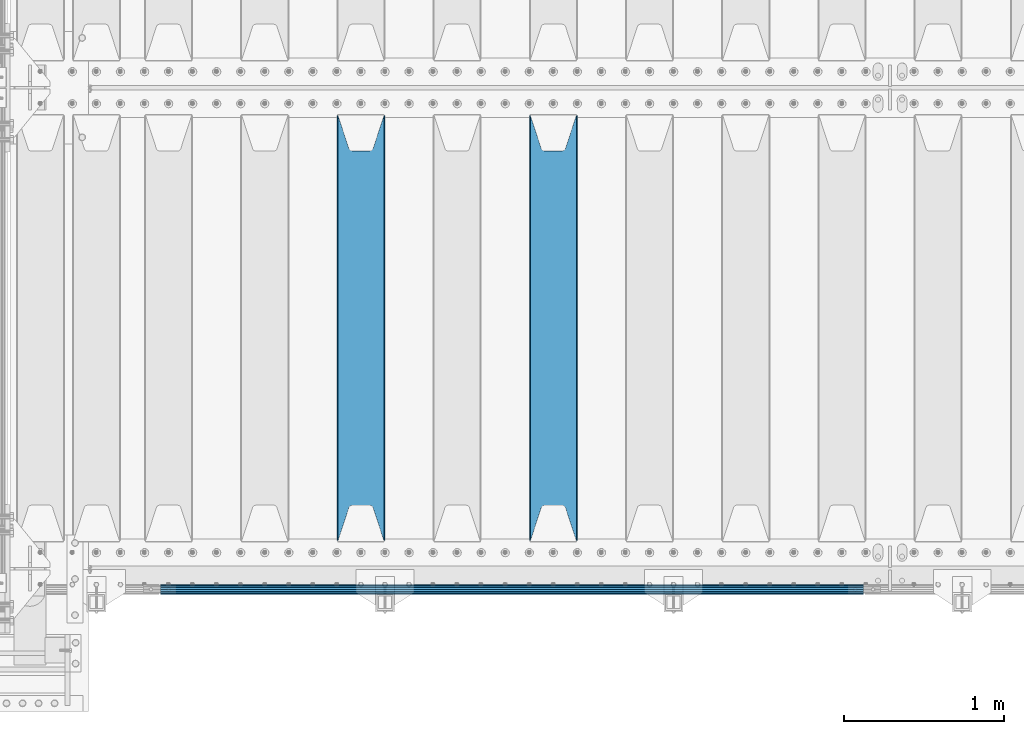
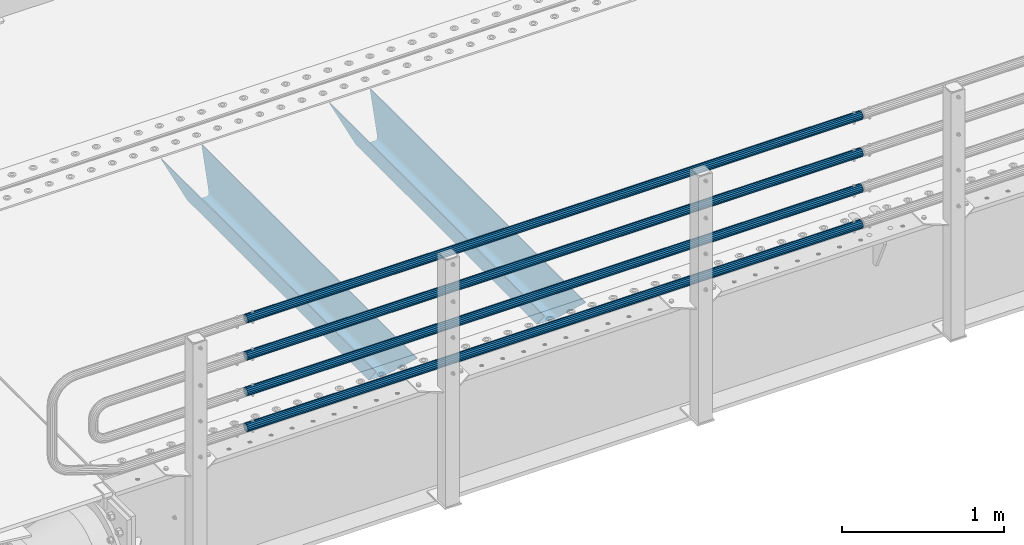
# One storey, part 91 of 208: 6 beams.
"""IFC2X3 building model written with IfcOpenShell, lengths in millimetres."""

import ifcopenshell
import ifcopenshell.guid

model = None  # the IFC model being written
_history = None  # IfcOwnerHistory: only IFC2X3 demands one
_inside = {}  # id of a spatial element -> (the spatial element, [elements in it])
_under = {}  # id of a project, library or spatial element -> (it, [spatial elements below it])
_declared = {}  # id of a project -> (the project, [libraries it declares])
_typed = {}  # id of a type object -> (the type object, [elements of that type])
_made_of = {}  # id of a material, layer set ... -> (it, [elements and type objects made of it])


def new_model(schema):
    """Start an empty IFC model of exactly this schema.

    Asked for "IFC4X3", IfcOpenShell would pick the latest addendum, in which some entities
    have other attributes; the version numbers below select the first issue.
    IFC2X3 requires an IfcOwnerHistory on every rooted entity: one is made here for all.
    """
    global model, _history
    if schema == "IFC4X3":
        model = ifcopenshell.file(schema_version=(4, 3, 0, 0))
    else:
        model = ifcopenshell.file(schema=schema)
    _inside.clear()
    _under.clear()
    _declared.clear()
    _typed.clear()
    _made_of.clear()
    _history = None
    if model.schema == "IFC2X3":
        org = make("IfcOrganization", Name="unknown")
        user = make(
            "IfcPersonAndOrganization",
            ThePerson=make("IfcPerson", FamilyName="unknown"),
            TheOrganization=org,
        )
        app = make(
            "IfcApplication",
            ApplicationDeveloper=org,
            Version="unknown",
            ApplicationFullName="unknown",
            ApplicationIdentifier="unknown",
        )
        _history = make(
            "IfcOwnerHistory",
            OwningUser=user,
            OwningApplication=app,
            ChangeAction="ADDED",
            CreationDate=0,
        )
    return model


def make(cls, **values):
    """One entity of the class cls with the attributes given. An attribute that is None is left unset."""
    return model.create_entity(
        cls, **{name: value for name, value in values.items() if value is not None}
    )


def rooted(cls, **values):
    """An entity with a GlobalId (a new one), such as an element, a storey or a relation."""
    return make(cls, GlobalId=ifcopenshell.guid.new(), OwnerHistory=_history, **values)


def si_unit(unit_type, name, prefix=None):
    """IfcSIUnit, for example si_unit("LENGTHUNIT", "METRE", prefix="MILLI")."""
    return make("IfcSIUnit", UnitType=unit_type, Prefix=prefix, Name=name)


def assignment(units):
    """IfcUnitAssignment: the units of a project."""
    return None if units is None else make("IfcUnitAssignment", Units=units)


def point(xyz):
    """IfcCartesianPoint."""
    return None if xyz is None else make("IfcCartesianPoint", Coordinates=xyz)


def direction(xyz):
    """IfcDirection."""
    return None if xyz is None else make("IfcDirection", DirectionRatios=xyz)


def frame(location, z_axis=None, x_axis=None):
    """IfcAxis2Placement3D, a coordinate frame: its origin and axes. An axis left out is left unset."""
    return make(
        "IfcAxis2Placement3D",
        Location=point(location),
        Axis=direction(z_axis),
        RefDirection=direction(x_axis),
    )


def origin_with_axes():
    """The frame at (0, 0, 0) with the z axis (0, 0, 1) and the x axis (1, 0, 0) written out."""
    return frame((0.0, 0.0, 0.0), z_axis=(0.0, 0.0, 1.0), x_axis=(1.0, 0.0, 0.0))


def place(relative_to, where):
    """IfcLocalPlacement: puts the frame where relative to a parent placement (None: the world)."""
    return make(
        "IfcLocalPlacement", PlacementRelTo=relative_to, RelativePlacement=where
    )


def context(
    kind, dimensions, precision=None, world=None, true_north=None, identifier=None
):
    """IfcGeometricRepresentationContext, for example the 3D "Model" context."""
    return make(
        "IfcGeometricRepresentationContext",
        ContextIdentifier=identifier,
        ContextType=kind,
        CoordinateSpaceDimension=dimensions,
        Precision=precision,
        WorldCoordinateSystem=world,
        TrueNorth=true_north,
    )


def subcontext(parent, identifier, kind, view, scale=None):
    """IfcGeometricRepresentationSubContext, for example "Body" below "Model"."""
    return make(
        "IfcGeometricRepresentationSubContext",
        ContextIdentifier=identifier,
        ContextType=kind,
        ParentContext=parent,
        TargetScale=scale,
        TargetView=view,
    )


def project(units=None, contexts=None):
    """IfcProject with its units and contexts."""
    return rooted(
        "IfcProject",
        Name="project",
        RepresentationContexts=contexts,
        UnitsInContext=assignment(units),
    )


def spatial(cls, under=None, at=None, **own):
    """A site, building, storey or space (cls), placed at a placement, below another one or the project."""
    s = rooted(cls, ObjectPlacement=at, **own)
    if under is not None:
        _under.setdefault(under.id(), (under, []))[1].append(s)
    return s


def faces_of(points, faces, orient=None, outer=None):
    """IfcFace entities. A face is a list of loops; a loop is a list of indices into points, from 0.

    orient and outer hold one flag for each loop. By default every Orientation is true, the
    first loop of a face is its IfcFaceOuterBound and the others are IfcFaceBound.
    """
    made = []
    for i, loops in enumerate(faces):
        bounds = []
        for j, loop in enumerate(loops):
            is_outer = j == 0 if outer is None else outer[i][j]
            bounds.append(
                make(
                    "IfcFaceOuterBound" if is_outer else "IfcFaceBound",
                    Bound=make("IfcPolyLoop", Polygon=[points[k] for k in loop]),
                    Orientation=True if orient is None else orient[i][j],
                )
            )
        made.append(make("IfcFace", Bounds=bounds))
    return made


def faceted_brep(points, faces, orient=None, outer=None, voids=None):
    """IfcFacetedBrep: a solid bounded by flat faces; with voids (closed shells), ...WithVoids."""
    shared = [point(p) for p in points]
    hull = make("IfcClosedShell", CfsFaces=faces_of(shared, faces, orient, outer))
    if voids is None:
        return make("IfcFacetedBrep", Outer=hull)
    return make(
        "IfcFacetedBrepWithVoids",
        Outer=hull,
        Voids=[
            make(cls, CfsFaces=faces_of(shared, fs, o, b)) for cls, fs, o, b in voids
        ],
    )


def shape(context_of_items, identifier, shape_type, items):
    """IfcShapeRepresentation: the items that make up one representation, for example the "Body"."""
    return make(
        "IfcShapeRepresentation",
        ContextOfItems=context_of_items,
        RepresentationIdentifier=identifier,
        RepresentationType=shape_type,
        Items=items,
    )


def material(Name=None, Category=None):
    """IfcMaterial."""
    return make("IfcMaterial", Name=Name, Category=Category)


def made_of(thing, what):
    """Note that an element or type object is made of a material, layer set ...; save() writes the relation."""
    if what is not None:
        _made_of.setdefault(what.id(), (what, []))[1].append(thing)
    return thing


def type_object(cls, material=None, **own):
    """A type object (cls), such as IfcWallType, which elements share."""
    return made_of(rooted(cls, **own), material)


def element(
    cls,
    number,
    at=None,
    inside=None,
    cuts=None,
    type_object=None,
    material=None,
    context=None,
    identifier="Body",
    shape_type=None,
    held_by="IfcProductDefinitionShape",
    body=None,
    shapes=None,
    **own,
):
    """One element of the class cls, such as IfcWall. Its Tag is "e" and its number.

    at: its placement. inside: the storey or other place that contains it. cuts: it is an
    opening in that element (IfcRelVoidsElement). A single representation is given by context,
    identifier, shape_type and body (its items); several are given by shapes. held_by: the class
    of the entity that holds the representations. save() writes the other relations.
    """
    e = rooted(cls, Tag="e%d" % number, ObjectPlacement=at, **own)
    if body is not None:
        shapes = [shape(context, identifier, shape_type, body)]
    if shapes is not None:
        e.Representation = make(held_by, Representations=shapes)
    if inside is not None:
        _inside.setdefault(inside.id(), (inside, []))[1].append(e)
    if cuts is not None:
        rooted(
            "IfcRelVoidsElement", RelatingBuildingElement=cuts, RelatedOpeningElement=e
        )
    if type_object is not None:
        _typed.setdefault(type_object.id(), (type_object, []))[1].append(e)
    return made_of(e, material)


def aggregate(whole, parts):
    """IfcRelAggregates: a whole, such as a stair, and the parts it consists of."""
    return rooted("IfcRelAggregates", RelatingObject=whole, RelatedObjects=parts)


def save(model, path):
    """Write the relations noted so far, then the file.

    IfcRelAggregates (storeys below a building ...), IfcRelContainedInSpatialStructure (elements
    in a storey), IfcRelDefinesByType, IfcRelAssociatesMaterial and IfcRelDeclares: one each for
    every whole, place, type object, material and project.
    """
    for whole, parts in _under.values():
        aggregate(whole, parts)
    for where, things in _inside.values():
        rooted(
            "IfcRelContainedInSpatialStructure",
            RelatedElements=things,
            RelatingStructure=where,
        )
    for kind, things in _typed.values():
        rooted("IfcRelDefinesByType", RelatedObjects=things, RelatingType=kind)
    for what, things in _made_of.values():
        rooted("IfcRelAssociatesMaterial", RelatedObjects=things, RelatingMaterial=what)
    for by, libraries in _declared.values():
        rooted("IfcRelDeclares", RelatingContext=by, RelatedDefinitions=libraries)
    model.write(path)


model = new_model("IFC2X3")

# Units and contexts
model_context = context("Model", 3, precision=1e-05, world=origin_with_axes())
body_context = subcontext(model_context, "Body", "Model", "MODEL_VIEW")
ifc_project = project(units=[si_unit("LENGTHUNIT", "METRE", prefix="MILLI"), si_unit("AREAUNIT", "SQUARE_METRE"), si_unit("VOLUMEUNIT", "CUBIC_METRE"), si_unit("MASSUNIT", "GRAM", prefix="KILO"), si_unit("TIMEUNIT", "SECOND"), si_unit("PLANEANGLEUNIT", "RADIAN"), si_unit("SOLIDANGLEUNIT", "STERADIAN"), si_unit("THERMODYNAMICTEMPERATUREUNIT", "DEGREE_CELSIUS"), si_unit("LUMINOUSINTENSITYUNIT", "LUMEN")], contexts=[model_context])

# Site, building, storey
site_placement = place(None, origin_with_axes())
site = spatial("IfcSite", under=ifc_project, at=site_placement, CompositionType="ELEMENT")
building_placement = place(site_placement, origin_with_axes())
building = spatial("IfcBuilding", under=site, at=building_placement, Name="Standard", CompositionType="ELEMENT")
storey_placement = place(building_placement, origin_with_axes())
storey = spatial("IfcBuildingStorey", under=building, at=storey_placement, Name="Undefined", CompositionType="ELEMENT", Elevation=0.0)

# Beams
ifc_material_1 = material(Name="STEEL/S355N")
beam_type_1 = type_object("IfcBeamType", PredefinedType="NOTDEFINED")
beam_1_placement = place(storey_placement, frame((-39050.0, 175.0, -115.0), z_axis=(0.0, 0.0, 1.0), x_axis=(0.0, 1.0, 0.0)))
element("IfcBeam", 1, at=beam_1_placement, inside=storey, type_object=beam_type_1, material=ifc_material_1, context=body_context, shape_type="Brep", body=[
    faceted_brep([(0.0, 150.0, 115.0), (0.0, 143.689999999999, 115.0), (2650.00000000297, 143.689999999999, 115.0), (2650.00000000297, 150.0, 115.0), (2650.00000000297, 142.059565218402, 110.0000000031), (2650.00000000297, 148.369565218403, 110.0000000031), (2441.90079219208, -80.1103600731112, -98.0992078077845), (2437.7588105432, -77.5672621345584, -102.241189456673), (2434.06523489746, -74.4080125315522, -105.934765102404), (2430.91086095089, -70.710272125576, -109.089139048974), (2428.37322971128, -66.5649389910068, -111.626770288588), (2426.51472138055, -62.0739139532889, -113.485278619323), (2425.38102192091, -57.3475956567672, -114.618978078955), (2424.99999999987, -52.5021667386536, -115.0), (2424.99999999987, 52.5021667386536, -115.0), (2425.38102192091, 57.3475956567672, -114.618978078955), (2426.51472138055, 62.0739139532889, -113.485278619323), (2428.37322971128, 66.5649389910068, -111.626770288588), (2430.91086095089, 70.710272125576, -109.089139048974), (2434.06523489746, 74.4080125315522, -105.934765102404), (2437.7588105432, 77.5672621345584, -102.241189456673), (2441.90079219208, 80.1103600731112, -98.0992078077846), (2446.38936140511, 81.9747917625791, -93.6106385947584), (2448.24948500409, 76.2713538057251, -91.7505149957729), (2444.62967112262, 74.76777986261, -95.3703288772456), (2441.28936334126, 72.7168944282894, -98.710636658607), (2438.31067330438, 70.1691124903846, -101.689326695487), (2435.76682334747, 67.1870637758839, -104.233176652398), (2433.72034654133, 63.8440531834895, -106.279653458539), (2432.22154950041, 60.222258798236, -107.778450499454), (2431.30727574265, 56.4107117849089, -108.692724257221), (2430.99999999987, 52.5031078186876, -109.0), (2430.99999999987, -52.5031078186876, -109.0), (2431.30727574265, -56.4107117849089, -108.692724257221), (2432.22154950041, -60.222258798236, -107.778450499454), (2433.72034654133, -63.8440531834895, -106.279653458539), (2435.76682334747, -67.1870637758839, -104.233176652398), (2438.31067330438, -70.1691124903846, -101.689326695487), (2441.28936334126, -72.7168944282894, -98.7106366586071), (2444.62967112262, -74.76777986261, -95.3703288772457), (2448.24948500409, -76.2713538057251, -91.7505149957729), (2650.00000000297, -142.059565218402, 110.0000000031), (2650.00000000297, -148.369565218403, 110.0000000031), (2446.38936140511, -81.9747917625791, -93.6106385947584), (2650.00000000297, -143.689999999999, 115.0), (2650.00000000297, -150.0, 115.0), (0.0, -143.689999999999, 115.0), (0.0, -150.0, 115.0), (0.0, -148.369565218261, 110.000000002663), (203.610638597421, -81.9747917625791, -93.6106385947584), (208.099207810448, -80.1103600731112, -98.0992078077845), (212.241189459336, -77.5672621345584, -102.241189456673), (215.934765105067, -74.4080125315522, -105.934765102404), (219.089139051637, -70.710272125576, -109.089139048974), (221.626770291251, -66.5649389910068, -111.626770288588), (223.485278621986, -62.0739139532889, -113.485278619323), (224.618978081618, -57.3475956567672, -114.618978078955), (225.000000002663, -52.5021667386536, -115.0), (225.000000002663, 52.5021667386536, -115.0), (224.618978081618, 57.3475956567672, -114.618978078955), (223.485278621986, 62.0739139532889, -113.485278619323), (221.626770291251, 66.5649389910068, -111.626770288588), (219.089139051637, 70.710272125576, -109.089139048974), (215.934765105067, 74.4080125315522, -105.934765102404), (212.241189459336, 77.5672621345584, -102.241189456673), (208.099207810448, 80.1103600731112, -98.0992078077846), (203.610638597421, 81.9747917625791, -93.6106385947584), (0.0, 148.369565218261, 110.000000002663), (0.0, 142.05956521826, 110.000000002663), (201.750514998436, 76.2713538057251, -91.7505149957729), (205.370328879908, 74.76777986261, -95.3703288772456), (208.71063666127, 72.7168944282894, -98.710636658607), (211.68932669815, 70.1691124903846, -101.689326695487), (214.233176655061, 67.1870637758839, -104.233176652398), (216.279653461202, 63.8440531834895, -106.279653458539), (217.778450502116, 60.222258798236, -107.778450499454), (218.692724259884, 56.4107117849089, -108.692724257221), (219.000000002663, 52.5031078186876, -109.0), (219.000000002663, -52.5031078186876, -109.0), (218.692724259884, -56.4107117849089, -108.692724257221), (217.778450502116, -60.222258798236, -107.778450499454), (216.279653461202, -63.8440531834895, -106.279653458539), (214.233176655061, -67.1870637758839, -104.233176652398), (211.68932669815, -70.1691124903846, -101.689326695487), (208.71063666127, -72.7168944282894, -98.7106366586071), (205.370328879908, -74.76777986261, -95.3703288772457), (201.750514998436, -76.2713538057251, -91.7505149957729), (0.0, -142.05956521826, 110.000000002663)], [[[0, 1, 2, 3]], [[3, 2, 4, 5]], [[6, 7, 8, 9, 10, 11, 12, 13, 14, 15, 16, 17, 18, 19, 20, 21, 22, 5, 4, 23, 24, 25, 26, 27, 28, 29, 30, 31, 32, 33, 34, 35, 36, 37, 38, 39, 40, 41, 42, 43]], [[44, 45, 42, 41]], [[46, 47, 45, 44]], [[43, 42, 45, 47, 48, 49]], [[6, 43, 49, 50]], [[7, 6, 50, 51]], [[8, 7, 51, 52]], [[9, 8, 52, 53]], [[10, 9, 53, 54]], [[11, 10, 54, 55]], [[12, 11, 55, 56]], [[13, 12, 56, 57]], [[14, 13, 57, 58]], [[15, 14, 58, 59]], [[16, 15, 59, 60]], [[17, 16, 60, 61]], [[18, 17, 61, 62]], [[19, 18, 62, 63]], [[20, 19, 63, 64]], [[21, 20, 64, 65]], [[22, 21, 65, 66]], [[0, 3, 5, 22, 66, 67]], [[1, 0, 67, 68]], [[23, 4, 2, 1, 68, 69]], [[24, 23, 69, 70]], [[25, 24, 70, 71]], [[26, 25, 71, 72]], [[27, 26, 72, 73]], [[28, 27, 73, 74]], [[29, 28, 74, 75]], [[30, 29, 75, 76]], [[31, 30, 76, 77]], [[32, 31, 77, 78]], [[33, 32, 78, 79]], [[34, 33, 79, 80]], [[35, 34, 80, 81]], [[36, 35, 81, 82]], [[37, 36, 82, 83]], [[38, 37, 83, 84]], [[39, 38, 84, 85]], [[40, 39, 85, 86]], [[46, 44, 41, 40, 86, 87]], [[47, 46, 87, 48]], [[86, 85, 84, 83, 82, 81, 80, 79, 78, 77, 76, 75, 74, 73, 72, 71, 70, 69, 68, 67, 66, 65, 64, 63, 62, 61, 60, 59, 58, 57, 56, 55, 54, 53, 52, 51, 50, 49, 48, 87]]]),
])
beam_2_placement = place(storey_placement, frame((-40250.0, 175.0, -115.0), z_axis=(0.0, 0.0, 1.0), x_axis=(0.0, 1.0, 0.0)))
element("IfcBeam", 2, at=beam_2_placement, inside=storey, type_object=beam_type_1, material=ifc_material_1, context=body_context, shape_type="Brep", body=[
    faceted_brep([(0.0, 150.0, 115.0), (0.0, 143.689999999999, 115.0), (2650.00000000297, 143.689999999999, 115.0), (2650.00000000297, 150.0, 115.0), (2650.00000000297, 142.059565218402, 110.0000000031), (2650.00000000297, 148.369565218403, 110.0000000031), (2441.90079219208, -80.1103600731112, -98.0992078077845), (2437.7588105432, -77.5672621345584, -102.241189456673), (2434.06523489746, -74.4080125315522, -105.934765102404), (2430.91086095089, -70.710272125576, -109.089139048974), (2428.37322971128, -66.5649389910068, -111.626770288588), (2426.51472138055, -62.0739139532889, -113.485278619323), (2425.38102192091, -57.3475956567672, -114.618978078955), (2424.99999999987, -52.5021667386536, -115.0), (2424.99999999987, 52.5021667386536, -115.0), (2425.38102192091, 57.3475956567672, -114.618978078955), (2426.51472138055, 62.0739139532889, -113.485278619323), (2428.37322971128, 66.5649389910068, -111.626770288588), (2430.91086095089, 70.710272125576, -109.089139048974), (2434.06523489746, 74.4080125315522, -105.934765102404), (2437.7588105432, 77.5672621345584, -102.241189456673), (2441.90079219208, 80.1103600731112, -98.0992078077846), (2446.38936140511, 81.9747917625791, -93.6106385947584), (2448.24948500409, 76.2713538057251, -91.7505149957729), (2444.62967112262, 74.76777986261, -95.3703288772456), (2441.28936334126, 72.7168944282894, -98.710636658607), (2438.31067330438, 70.1691124903846, -101.689326695487), (2435.76682334747, 67.1870637758839, -104.233176652398), (2433.72034654133, 63.8440531834895, -106.279653458539), (2432.22154950041, 60.222258798236, -107.778450499454), (2431.30727574265, 56.4107117849089, -108.692724257221), (2430.99999999987, 52.5031078186876, -109.0), (2430.99999999987, -52.5031078186876, -109.0), (2431.30727574265, -56.4107117849089, -108.692724257221), (2432.22154950041, -60.222258798236, -107.778450499454), (2433.72034654133, -63.8440531834895, -106.279653458539), (2435.76682334747, -67.1870637758839, -104.233176652398), (2438.31067330438, -70.1691124903846, -101.689326695487), (2441.28936334126, -72.7168944282894, -98.7106366586071), (2444.62967112262, -74.76777986261, -95.3703288772457), (2448.24948500409, -76.2713538057251, -91.7505149957729), (2650.00000000297, -142.059565218402, 110.0000000031), (2650.00000000297, -148.369565218403, 110.0000000031), (2446.38936140511, -81.9747917625791, -93.6106385947584), (2650.00000000297, -143.689999999999, 115.0), (2650.00000000297, -150.0, 115.0), (0.0, -143.689999999999, 115.0), (0.0, -150.0, 115.0), (0.0, -148.369565218261, 110.000000002663), (203.610638597421, -81.9747917625791, -93.6106385947584), (208.099207810448, -80.1103600731112, -98.0992078077845), (212.241189459336, -77.5672621345584, -102.241189456673), (215.934765105067, -74.4080125315522, -105.934765102404), (219.089139051637, -70.710272125576, -109.089139048974), (221.626770291251, -66.5649389910068, -111.626770288588), (223.485278621986, -62.0739139532889, -113.485278619323), (224.618978081618, -57.3475956567672, -114.618978078955), (225.000000002663, -52.5021667386536, -115.0), (225.000000002663, 52.5021667386536, -115.0), (224.618978081618, 57.3475956567672, -114.618978078955), (223.485278621986, 62.0739139532889, -113.485278619323), (221.626770291251, 66.5649389910068, -111.626770288588), (219.089139051637, 70.710272125576, -109.089139048974), (215.934765105067, 74.4080125315522, -105.934765102404), (212.241189459336, 77.5672621345584, -102.241189456673), (208.099207810448, 80.1103600731112, -98.0992078077846), (203.610638597421, 81.9747917625791, -93.6106385947584), (0.0, 148.369565218261, 110.000000002663), (0.0, 142.05956521826, 110.000000002663), (201.750514998436, 76.2713538057251, -91.7505149957729), (205.370328879908, 74.76777986261, -95.3703288772456), (208.71063666127, 72.7168944282894, -98.710636658607), (211.68932669815, 70.1691124903846, -101.689326695487), (214.233176655061, 67.1870637758839, -104.233176652398), (216.279653461202, 63.8440531834895, -106.279653458539), (217.778450502116, 60.222258798236, -107.778450499454), (218.692724259884, 56.4107117849089, -108.692724257221), (219.000000002663, 52.5031078186876, -109.0), (219.000000002663, -52.5031078186876, -109.0), (218.692724259884, -56.4107117849089, -108.692724257221), (217.778450502116, -60.222258798236, -107.778450499454), (216.279653461202, -63.8440531834895, -106.279653458539), (214.233176655061, -67.1870637758839, -104.233176652398), (211.68932669815, -70.1691124903846, -101.689326695487), (208.71063666127, -72.7168944282894, -98.7106366586071), (205.370328879908, -74.76777986261, -95.3703288772457), (201.750514998436, -76.2713538057251, -91.7505149957729), (0.0, -142.05956521826, 110.000000002663)], [[[0, 1, 2, 3]], [[3, 2, 4, 5]], [[6, 7, 8, 9, 10, 11, 12, 13, 14, 15, 16, 17, 18, 19, 20, 21, 22, 5, 4, 23, 24, 25, 26, 27, 28, 29, 30, 31, 32, 33, 34, 35, 36, 37, 38, 39, 40, 41, 42, 43]], [[44, 45, 42, 41]], [[46, 47, 45, 44]], [[43, 42, 45, 47, 48, 49]], [[6, 43, 49, 50]], [[7, 6, 50, 51]], [[8, 7, 51, 52]], [[9, 8, 52, 53]], [[10, 9, 53, 54]], [[11, 10, 54, 55]], [[12, 11, 55, 56]], [[13, 12, 56, 57]], [[14, 13, 57, 58]], [[15, 14, 58, 59]], [[16, 15, 59, 60]], [[17, 16, 60, 61]], [[18, 17, 61, 62]], [[19, 18, 62, 63]], [[20, 19, 63, 64]], [[21, 20, 64, 65]], [[22, 21, 65, 66]], [[0, 3, 5, 22, 66, 67]], [[1, 0, 67, 68]], [[23, 4, 2, 1, 68, 69]], [[24, 23, 69, 70]], [[25, 24, 70, 71]], [[26, 25, 71, 72]], [[27, 26, 72, 73]], [[28, 27, 73, 74]], [[29, 28, 74, 75]], [[30, 29, 75, 76]], [[31, 30, 76, 77]], [[32, 31, 77, 78]], [[33, 32, 78, 79]], [[34, 33, 79, 80]], [[35, 34, 80, 81]], [[36, 35, 81, 82]], [[37, 36, 82, 83]], [[38, 37, 83, 84]], [[39, 38, 84, 85]], [[40, 39, 85, 86]], [[46, 44, 41, 40, 86, 87]], [[47, 46, 87, 48]], [[86, 85, 84, 83, 82, 81, 80, 79, 78, 77, 76, 75, 74, 73, 72, 71, 70, 69, 68, 67, 66, 65, 64, 63, 62, 61, 60, 59, 58, 57, 56, 55, 54, 53, 52, 51, 50, 49, 48, 87]]]),
])
ifc_material_2 = material()
beam_type_2 = type_object("IfcBeamType", PredefinedType="NOTDEFINED")
beam_3_placement = place(storey_placement, frame((-37116.0000000001, -129.849999999907, 149.849999999725), z_axis=(0.0, 0.0, -1.0), x_axis=(-1.0, 0.0, 0.0)))
element("IfcBeam", 3, at=beam_3_placement, inside=storey, type_object=beam_type_2, material=ifc_material_2, context=body_context, shape_type="Brep", body=[
    faceted_brep([(0.0, -26.5500000000002, 0.0), (0.0, -24.5290015881747, 10.1602451292931), (4384.00249699992, -24.5290015881747, 10.1602451292931), (4384.00249699992, -26.5500000000002, 0.0), (0.0, -18.7736850405026, 18.7736850405028), (4384.00249699992, -18.7736850405026, 18.7736850405028), (0.0, -10.1602451292929, 24.5290015881747), (4384.00249699992, -10.1602451292929, 24.5290015881747), (0.0, 0.0, 26.55), (4384.00249699992, 0.0, 26.55), (0.0, 10.1602451292929, 24.5290015881747), (4384.00249699992, 10.1602451292929, 24.5290015881747), (0.0, 18.7736850405026, 18.7736850405028), (4384.00249699992, 18.7736850405026, 18.7736850405028), (0.0, 24.5290015881747, 10.1602451292931), (4384.00249699992, 24.5290015881747, 10.1602451292931), (0.0, 26.5500000000002, 0.0), (4384.00249699992, 26.5500000000002, 0.0), (0.0, 24.5290015881747, -10.1602451292931), (4384.00249699992, 24.5290015881747, -10.1602451292931), (0.0, 18.7736850405026, -18.7736850405028), (4384.00249699992, 18.7736850405026, -18.7736850405028), (0.0, 10.1602451292929, -24.5290015881747), (4384.00249699992, 10.1602451292929, -24.5290015881747), (0.0, 0.0, -26.55), (4384.00249699992, 0.0, -26.55), (0.0, -10.1602451292929, -24.5290015881747), (4384.00249699992, -10.1602451292929, -24.5290015881747), (0.0, -18.7736850405026, -18.7736850405028), (4384.00249699992, -18.7736850405026, -18.7736850405028), (0.0, -24.5290015881747, -10.1602451292931), (4384.00249699992, -24.5290015881747, -10.1602451292931), (0.0, -30.1499999999996, 0.0), (0.0, -27.8549679052148, -11.5379054858058), (4384.00249699992, -27.8549679052148, -11.5379054858075), (4384.00249699992, -30.1499999999996, 0.0), (0.0, -21.3192694527743, -21.3192694527752), (4384.00249699992, -21.3192694527743, -21.3192694527744), (0.0, -11.5379054858076, -27.8549679052157), (4384.00249699992, -11.5379054858076, -27.8549679052153), (0.0, 0.0, -30.1500000000015), (4384.00249699992, 0.0, -30.15), (0.0, 11.5379054858076, -27.8549679052157), (4384.00249699992, 11.5379054858076, -27.8549679052153), (0.0, 21.3192694527743, -21.3192694527752), (4384.00249699992, 21.3192694527743, -21.3192694527744), (0.0, 27.8549679052157, -11.5379054858058), (4384.00249699992, 27.8549679052157, -11.5379054858074), (0.0, 30.1499999999996, 0.0), (4384.00249699992, 30.1499999999996, 0.0), (0.0, 27.8549679052157, 11.5379054858058), (4384.00249699992, 27.8549679052157, 11.5379054858075), (0.0, 21.3192694527743, 21.3192694527752), (4384.00249699992, 21.3192694527743, 21.3192694527744), (0.0, 11.5379054858076, 27.8549679052157), (4384.00249699992, 11.5379054858076, 27.8549679052153), (0.0, 0.0, 30.1500000000015), (4384.00249699992, 0.0, 30.15), (0.0, -11.5379054858076, 27.8549679052157), (4384.00249699992, -11.5379054858076, 27.8549679052153), (0.0, -21.3192694527743, 21.3192694527752), (4384.00249699992, -21.3192694527743, 21.3192694527744), (0.0, -27.8549679052157, 11.5379054858058), (4384.00249699992, -27.8549679052157, 11.5379054858075)], [[[0, 1, 2, 3]], [[1, 4, 5, 2]], [[4, 6, 7, 5]], [[6, 8, 9, 7]], [[8, 10, 11, 9]], [[10, 12, 13, 11]], [[12, 14, 15, 13]], [[14, 16, 17, 15]], [[16, 18, 19, 17]], [[18, 20, 21, 19]], [[20, 22, 23, 21]], [[22, 24, 25, 23]], [[24, 26, 27, 25]], [[26, 28, 29, 27]], [[28, 30, 31, 29]], [[30, 0, 3, 31]], [[32, 33, 34, 35]], [[33, 36, 37, 34]], [[36, 38, 39, 37]], [[38, 40, 41, 39]], [[40, 42, 43, 41]], [[42, 44, 45, 43]], [[44, 46, 47, 45]], [[46, 48, 49, 47]], [[48, 50, 51, 49]], [[50, 52, 53, 51]], [[52, 54, 55, 53]], [[54, 56, 57, 55]], [[56, 58, 59, 57]], [[58, 60, 61, 59]], [[60, 62, 63, 61]], [[62, 32, 35, 63]], [[37, 39, 41, 43, 45, 47, 49, 51, 53, 55, 57, 59, 61, 63, 35, 34], [5, 7, 9, 11, 13, 15, 17, 19, 21, 23, 25, 27, 29, 31, 3, 2]], [[62, 60, 58, 56, 54, 52, 50, 48, 46, 44, 42, 40, 38, 36, 33, 32], [30, 28, 26, 24, 22, 20, 18, 16, 14, 12, 10, 8, 6, 4, 1, 0]]]),
])
beam_4_placement = place(storey_placement, frame((-37116.0000000001, -129.849999999907, 420.149999999728), z_axis=(0.0, 0.0, -1.0), x_axis=(-1.0, 0.0, 0.0)))
element("IfcBeam", 4, at=beam_4_placement, inside=storey, type_object=beam_type_2, material=ifc_material_2, context=body_context, shape_type="Brep", body=[
    faceted_brep([(0.0, -26.5500000000002, 0.0), (0.0, -24.5290015881747, 10.1602451292931), (4384.00249699992, -24.5290015881747, 10.1602451292931), (4384.00249699992, -26.5500000000002, 0.0), (0.0, -18.7736850405026, 18.7736850405028), (4384.00249699992, -18.7736850405026, 18.7736850405028), (0.0, -10.1602451292929, 24.5290015881747), (4384.00249699992, -10.1602451292929, 24.5290015881747), (0.0, 0.0, 26.55), (4384.00249699992, 0.0, 26.55), (0.0, 10.1602451292929, 24.5290015881747), (4384.00249699992, 10.1602451292929, 24.5290015881747), (0.0, 18.7736850405026, 18.7736850405028), (4384.00249699992, 18.7736850405026, 18.7736850405028), (0.0, 24.5290015881747, 10.1602451292931), (4384.00249699992, 24.5290015881747, 10.1602451292931), (0.0, 26.5500000000002, 0.0), (4384.00249699992, 26.5500000000002, 0.0), (0.0, 24.5290015881747, -10.1602451292931), (4384.00249699992, 24.5290015881747, -10.1602451292931), (0.0, 18.7736850405026, -18.7736850405028), (4384.00249699992, 18.7736850405026, -18.7736850405028), (0.0, 10.1602451292929, -24.5290015881747), (4384.00249699992, 10.1602451292929, -24.5290015881747), (0.0, 0.0, -26.55), (4384.00249699992, 0.0, -26.55), (0.0, -10.1602451292929, -24.5290015881747), (4384.00249699992, -10.1602451292929, -24.5290015881747), (0.0, -18.7736850405026, -18.7736850405028), (4384.00249699992, -18.7736850405026, -18.7736850405028), (0.0, -24.5290015881747, -10.1602451292931), (4384.00249699992, -24.5290015881747, -10.1602451292931), (0.0, -30.1499999999996, 0.0), (0.0, -27.8549679052148, -11.5379054858058), (4384.00249699992, -27.8549679052148, -11.5379054858075), (4384.00249699992, -30.1499999999996, 0.0), (0.0, -21.3192694527743, -21.3192694527752), (4384.00249699992, -21.3192694527743, -21.3192694527744), (0.0, -11.5379054858076, -27.8549679052157), (4384.00249699992, -11.5379054858076, -27.8549679052153), (0.0, 0.0, -30.1500000000015), (4384.00249699992, 0.0, -30.15), (0.0, 11.5379054858076, -27.8549679052157), (4384.00249699992, 11.5379054858076, -27.8549679052153), (0.0, 21.3192694527743, -21.3192694527752), (4384.00249699992, 21.3192694527743, -21.3192694527744), (0.0, 27.8549679052157, -11.5379054858058), (4384.00249699992, 27.8549679052157, -11.5379054858074), (0.0, 30.1499999999996, 0.0), (4384.00249699992, 30.1499999999996, 0.0), (0.0, 27.8549679052157, 11.5379054858058), (4384.00249699992, 27.8549679052157, 11.5379054858075), (0.0, 21.3192694527743, 21.3192694527752), (4384.00249699992, 21.3192694527743, 21.3192694527744), (0.0, 11.5379054858076, 27.8549679052157), (4384.00249699992, 11.5379054858076, 27.8549679052153), (0.0, 0.0, 30.1500000000015), (4384.00249699992, 0.0, 30.15), (0.0, -11.5379054858076, 27.8549679052157), (4384.00249699992, -11.5379054858076, 27.8549679052153), (0.0, -21.3192694527743, 21.3192694527752), (4384.00249699992, -21.3192694527743, 21.3192694527744), (0.0, -27.8549679052157, 11.5379054858058), (4384.00249699992, -27.8549679052157, 11.5379054858075)], [[[0, 1, 2, 3]], [[1, 4, 5, 2]], [[4, 6, 7, 5]], [[6, 8, 9, 7]], [[8, 10, 11, 9]], [[10, 12, 13, 11]], [[12, 14, 15, 13]], [[14, 16, 17, 15]], [[16, 18, 19, 17]], [[18, 20, 21, 19]], [[20, 22, 23, 21]], [[22, 24, 25, 23]], [[24, 26, 27, 25]], [[26, 28, 29, 27]], [[28, 30, 31, 29]], [[30, 0, 3, 31]], [[32, 33, 34, 35]], [[33, 36, 37, 34]], [[36, 38, 39, 37]], [[38, 40, 41, 39]], [[40, 42, 43, 41]], [[42, 44, 45, 43]], [[44, 46, 47, 45]], [[46, 48, 49, 47]], [[48, 50, 51, 49]], [[50, 52, 53, 51]], [[52, 54, 55, 53]], [[54, 56, 57, 55]], [[56, 58, 59, 57]], [[58, 60, 61, 59]], [[60, 62, 63, 61]], [[62, 32, 35, 63]], [[37, 39, 41, 43, 45, 47, 49, 51, 53, 55, 57, 59, 61, 63, 35, 34], [5, 7, 9, 11, 13, 15, 17, 19, 21, 23, 25, 27, 29, 31, 3, 2]], [[62, 60, 58, 56, 54, 52, 50, 48, 46, 44, 42, 40, 38, 36, 33, 32], [30, 28, 26, 24, 22, 20, 18, 16, 14, 12, 10, 8, 6, 4, 1, 0]]]),
])
beam_5_placement = place(storey_placement, frame((-37116.0000000001, -129.849999999907, 969.849999999725), z_axis=(0.0, 0.0, -1.0), x_axis=(-1.0, 0.0, 0.0)))
element("IfcBeam", 5, at=beam_5_placement, inside=storey, type_object=beam_type_2, material=ifc_material_2, context=body_context, shape_type="Brep", body=[
    faceted_brep([(0.0, -26.5500000000002, 0.0), (0.0, -24.5290015881747, 10.1602451292931), (4384.00249699992, -24.5290015881747, 10.1602451292931), (4384.00249699992, -26.5500000000002, 0.0), (0.0, -18.7736850405026, 18.7736850405028), (4384.00249699992, -18.7736850405026, 18.7736850405028), (0.0, -10.1602451292929, 24.5290015881747), (4384.00249699992, -10.1602451292929, 24.5290015881747), (0.0, 0.0, 26.55), (4384.00249699992, 0.0, 26.55), (0.0, 10.1602451292929, 24.5290015881747), (4384.00249699992, 10.1602451292929, 24.5290015881747), (0.0, 18.7736850405026, 18.7736850405028), (4384.00249699992, 18.7736850405026, 18.7736850405028), (0.0, 24.5290015881747, 10.1602451292931), (4384.00249699992, 24.5290015881747, 10.1602451292931), (0.0, 26.5500000000002, 0.0), (4384.00249699992, 26.5500000000002, 0.0), (0.0, 24.5290015881747, -10.1602451292931), (4384.00249699992, 24.5290015881747, -10.1602451292931), (0.0, 18.7736850405026, -18.7736850405028), (4384.00249699992, 18.7736850405026, -18.7736850405028), (0.0, 10.1602451292929, -24.5290015881747), (4384.00249699992, 10.1602451292929, -24.5290015881747), (0.0, 0.0, -26.55), (4384.00249699992, 0.0, -26.55), (0.0, -10.1602451292929, -24.5290015881747), (4384.00249699992, -10.1602451292929, -24.5290015881747), (0.0, -18.7736850405026, -18.7736850405028), (4384.00249699992, -18.7736850405026, -18.7736850405028), (0.0, -24.5290015881747, -10.1602451292931), (4384.00249699992, -24.5290015881747, -10.1602451292931), (0.0, -30.1499999999996, 0.0), (0.0, -27.8549679052148, -11.5379054858058), (4384.00249699992, -27.8549679052148, -11.5379054858075), (4384.00249699992, -30.1499999999996, 0.0), (0.0, -21.3192694527743, -21.3192694527752), (4384.00249699992, -21.3192694527743, -21.3192694527744), (0.0, -11.5379054858076, -27.8549679052157), (4384.00249699992, -11.5379054858076, -27.8549679052153), (0.0, 0.0, -30.1500000000015), (4384.00249699992, 0.0, -30.15), (0.0, 11.5379054858076, -27.8549679052157), (4384.00249699992, 11.5379054858076, -27.8549679052153), (0.0, 21.3192694527743, -21.3192694527752), (4384.00249699992, 21.3192694527743, -21.3192694527744), (0.0, 27.8549679052157, -11.5379054858058), (4384.00249699992, 27.8549679052157, -11.5379054858074), (0.0, 30.1499999999996, 0.0), (4384.00249699992, 30.1499999999996, 0.0), (0.0, 27.8549679052157, 11.5379054858058), (4384.00249699992, 27.8549679052157, 11.5379054858075), (0.0, 21.3192694527743, 21.3192694527752), (4384.00249699992, 21.3192694527743, 21.3192694527744), (0.0, 11.5379054858076, 27.8549679052157), (4384.00249699992, 11.5379054858076, 27.8549679052153), (0.0, 0.0, 30.1500000000015), (4384.00249699992, 0.0, 30.15), (0.0, -11.5379054858076, 27.8549679052157), (4384.00249699992, -11.5379054858076, 27.8549679052153), (0.0, -21.3192694527743, 21.3192694527752), (4384.00249699992, -21.3192694527743, 21.3192694527744), (0.0, -27.8549679052157, 11.5379054858058), (4384.00249699992, -27.8549679052157, 11.5379054858075)], [[[0, 1, 2, 3]], [[1, 4, 5, 2]], [[4, 6, 7, 5]], [[6, 8, 9, 7]], [[8, 10, 11, 9]], [[10, 12, 13, 11]], [[12, 14, 15, 13]], [[14, 16, 17, 15]], [[16, 18, 19, 17]], [[18, 20, 21, 19]], [[20, 22, 23, 21]], [[22, 24, 25, 23]], [[24, 26, 27, 25]], [[26, 28, 29, 27]], [[28, 30, 31, 29]], [[30, 0, 3, 31]], [[32, 33, 34, 35]], [[33, 36, 37, 34]], [[36, 38, 39, 37]], [[38, 40, 41, 39]], [[40, 42, 43, 41]], [[42, 44, 45, 43]], [[44, 46, 47, 45]], [[46, 48, 49, 47]], [[48, 50, 51, 49]], [[50, 52, 53, 51]], [[52, 54, 55, 53]], [[54, 56, 57, 55]], [[56, 58, 59, 57]], [[58, 60, 61, 59]], [[60, 62, 63, 61]], [[62, 32, 35, 63]], [[37, 39, 41, 43, 45, 47, 49, 51, 53, 55, 57, 59, 61, 63, 35, 34], [5, 7, 9, 11, 13, 15, 17, 19, 21, 23, 25, 27, 29, 31, 3, 2]], [[62, 60, 58, 56, 54, 52, 50, 48, 46, 44, 42, 40, 38, 36, 33, 32], [30, 28, 26, 24, 22, 20, 18, 16, 14, 12, 10, 8, 6, 4, 1, 0]]]),
])
beam_6_placement = place(storey_placement, frame((-37116.0000000001, -129.849999999907, 689.849999999725), z_axis=(0.0, 0.0, -1.0), x_axis=(-1.0, 0.0, 0.0)))
element("IfcBeam", 6, at=beam_6_placement, inside=storey, type_object=beam_type_2, material=ifc_material_2, context=body_context, shape_type="Brep", body=[
    faceted_brep([(0.0, -26.5500000000002, 0.0), (0.0, -24.5290015881747, 10.1602451292931), (4384.00249699992, -24.5290015881747, 10.1602451292931), (4384.00249699992, -26.5500000000002, 0.0), (0.0, -18.7736850405026, 18.7736850405028), (4384.00249699992, -18.7736850405026, 18.7736850405028), (0.0, -10.1602451292929, 24.5290015881747), (4384.00249699992, -10.1602451292929, 24.5290015881747), (0.0, 0.0, 26.55), (4384.00249699992, 0.0, 26.55), (0.0, 10.1602451292929, 24.5290015881747), (4384.00249699992, 10.1602451292929, 24.5290015881747), (0.0, 18.7736850405026, 18.7736850405028), (4384.00249699992, 18.7736850405026, 18.7736850405028), (0.0, 24.5290015881747, 10.1602451292931), (4384.00249699992, 24.5290015881747, 10.1602451292931), (0.0, 26.5500000000002, 0.0), (4384.00249699992, 26.5500000000002, 0.0), (0.0, 24.5290015881747, -10.1602451292931), (4384.00249699992, 24.5290015881747, -10.1602451292931), (0.0, 18.7736850405026, -18.7736850405028), (4384.00249699992, 18.7736850405026, -18.7736850405028), (0.0, 10.1602451292929, -24.5290015881747), (4384.00249699992, 10.1602451292929, -24.5290015881747), (0.0, 0.0, -26.55), (4384.00249699992, 0.0, -26.55), (0.0, -10.1602451292929, -24.5290015881747), (4384.00249699992, -10.1602451292929, -24.5290015881747), (0.0, -18.7736850405026, -18.7736850405028), (4384.00249699992, -18.7736850405026, -18.7736850405028), (0.0, -24.5290015881747, -10.1602451292931), (4384.00249699992, -24.5290015881747, -10.1602451292931), (0.0, -30.1499999999996, 0.0), (0.0, -27.8549679052148, -11.5379054858058), (4384.00249699992, -27.8549679052148, -11.5379054858075), (4384.00249699992, -30.1499999999996, 0.0), (0.0, -21.3192694527743, -21.3192694527752), (4384.00249699992, -21.3192694527743, -21.3192694527744), (0.0, -11.5379054858076, -27.8549679052157), (4384.00249699992, -11.5379054858076, -27.8549679052153), (0.0, 0.0, -30.1500000000015), (4384.00249699992, 0.0, -30.15), (0.0, 11.5379054858076, -27.8549679052157), (4384.00249699992, 11.5379054858076, -27.8549679052153), (0.0, 21.3192694527743, -21.3192694527752), (4384.00249699992, 21.3192694527743, -21.3192694527744), (0.0, 27.8549679052157, -11.5379054858058), (4384.00249699992, 27.8549679052157, -11.5379054858074), (0.0, 30.1499999999996, 0.0), (4384.00249699992, 30.1499999999996, 0.0), (0.0, 27.8549679052157, 11.5379054858058), (4384.00249699992, 27.8549679052157, 11.5379054858075), (0.0, 21.3192694527743, 21.3192694527752), (4384.00249699992, 21.3192694527743, 21.3192694527744), (0.0, 11.5379054858076, 27.8549679052157), (4384.00249699992, 11.5379054858076, 27.8549679052153), (0.0, 0.0, 30.1500000000015), (4384.00249699992, 0.0, 30.15), (0.0, -11.5379054858076, 27.8549679052157), (4384.00249699992, -11.5379054858076, 27.8549679052153), (0.0, -21.3192694527743, 21.3192694527752), (4384.00249699992, -21.3192694527743, 21.3192694527744), (0.0, -27.8549679052157, 11.5379054858058), (4384.00249699992, -27.8549679052157, 11.5379054858075)], [[[0, 1, 2, 3]], [[1, 4, 5, 2]], [[4, 6, 7, 5]], [[6, 8, 9, 7]], [[8, 10, 11, 9]], [[10, 12, 13, 11]], [[12, 14, 15, 13]], [[14, 16, 17, 15]], [[16, 18, 19, 17]], [[18, 20, 21, 19]], [[20, 22, 23, 21]], [[22, 24, 25, 23]], [[24, 26, 27, 25]], [[26, 28, 29, 27]], [[28, 30, 31, 29]], [[30, 0, 3, 31]], [[32, 33, 34, 35]], [[33, 36, 37, 34]], [[36, 38, 39, 37]], [[38, 40, 41, 39]], [[40, 42, 43, 41]], [[42, 44, 45, 43]], [[44, 46, 47, 45]], [[46, 48, 49, 47]], [[48, 50, 51, 49]], [[50, 52, 53, 51]], [[52, 54, 55, 53]], [[54, 56, 57, 55]], [[56, 58, 59, 57]], [[58, 60, 61, 59]], [[60, 62, 63, 61]], [[62, 32, 35, 63]], [[37, 39, 41, 43, 45, 47, 49, 51, 53, 55, 57, 59, 61, 63, 35, 34], [5, 7, 9, 11, 13, 15, 17, 19, 21, 23, 25, 27, 29, 31, 3, 2]], [[62, 60, 58, 56, 54, 52, 50, 48, 46, 44, 42, 40, 38, 36, 33, 32], [30, 28, 26, 24, 22, 20, 18, 16, 14, 12, 10, 8, 6, 4, 1, 0]]]),
])

save(model, "model.ifc")
